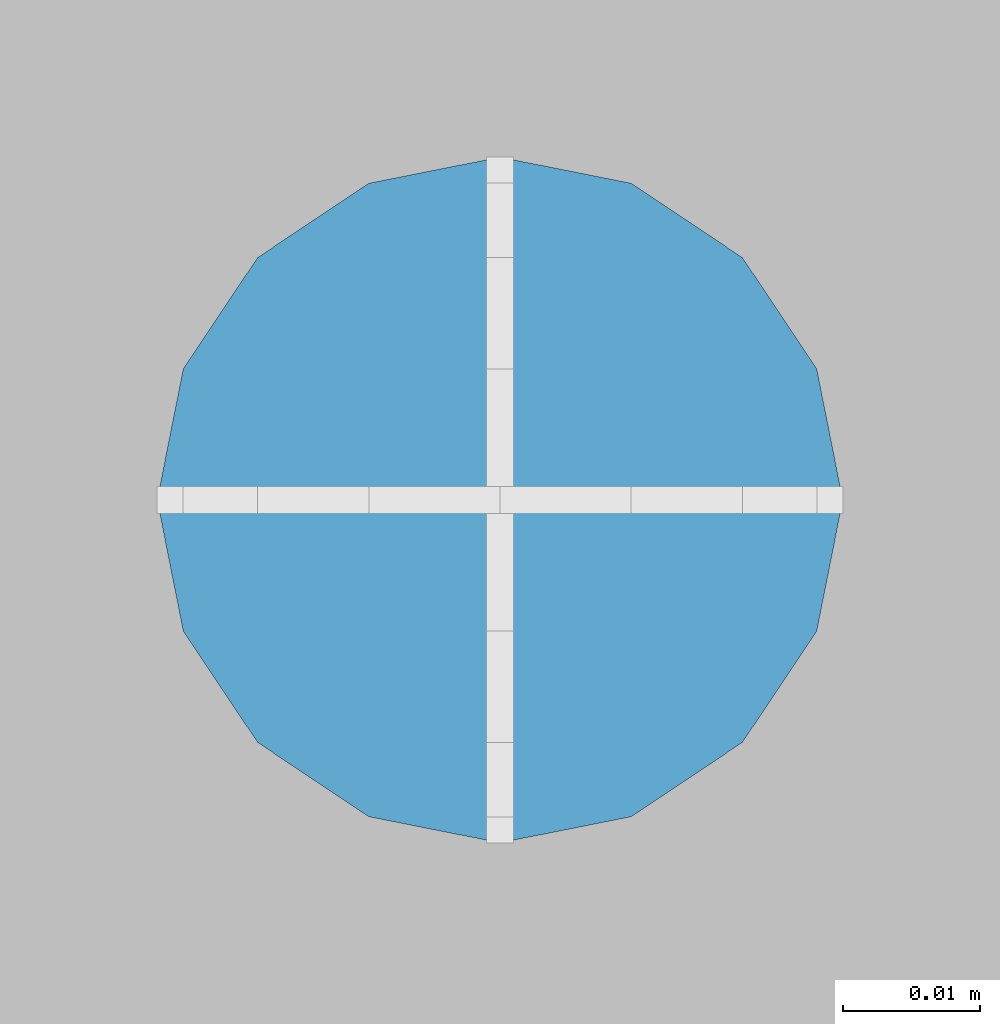
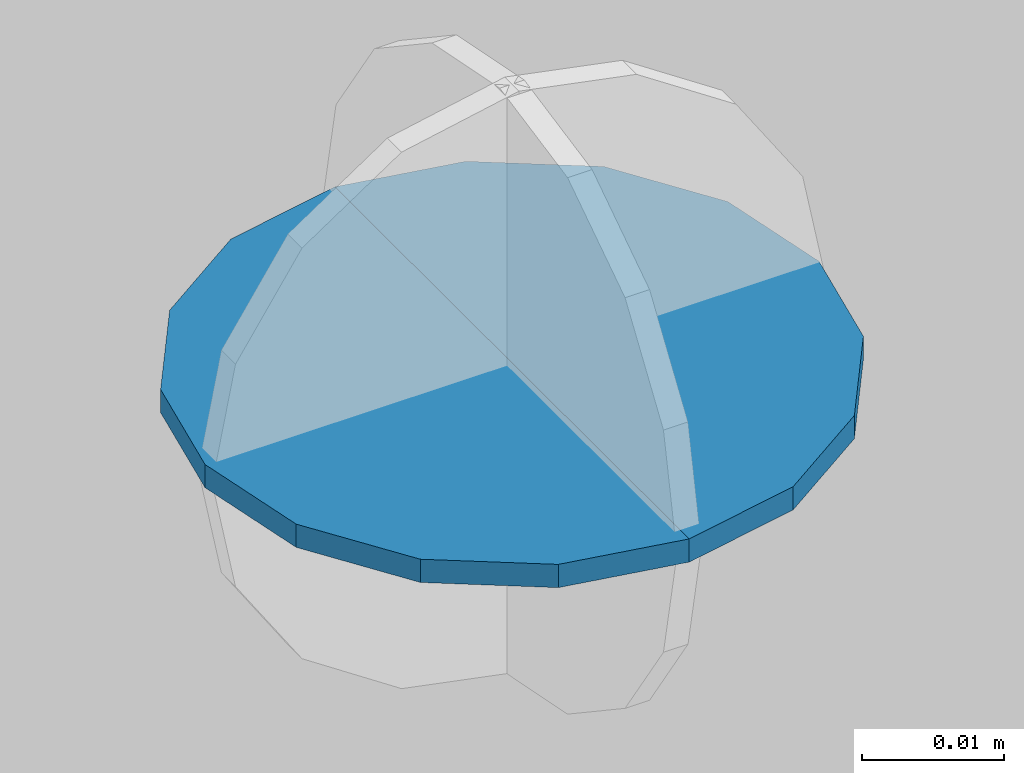
# One storey, part 74 of 350: 2 columns, 3 elements without a shape of their own.
"""IFC2X3 building model written with IfcOpenShell, lengths in millimetres."""

from ifc_helpers import new_model, si_unit, frame, origin_with_axes, place, context, subcontext, project, spatial, faceted_brep, material, type_object, element, aggregate, save


model = new_model("IFC2X3")

# Units and contexts
model_context = context("Model", 3, precision=1e-05, world=origin_with_axes())
body_context = subcontext(model_context, "Body", "Model", "MODEL_VIEW")
ifc_project = project(units=[si_unit("LENGTHUNIT", "METRE", prefix="MILLI"), si_unit("AREAUNIT", "SQUARE_METRE"), si_unit("VOLUMEUNIT", "CUBIC_METRE"), si_unit("MASSUNIT", "GRAM", prefix="KILO"), si_unit("TIMEUNIT", "SECOND"), si_unit("PLANEANGLEUNIT", "RADIAN"), si_unit("SOLIDANGLEUNIT", "STERADIAN"), si_unit("THERMODYNAMICTEMPERATUREUNIT", "DEGREE_CELSIUS"), si_unit("LUMINOUSINTENSITYUNIT", "LUMEN")], contexts=[model_context])

# Site, building, storey
site_placement = place(None, origin_with_axes())
site = spatial("IfcSite", under=ifc_project, at=site_placement, CompositionType="ELEMENT")
building_placement = place(site_placement, origin_with_axes())
building = spatial("IfcBuilding", under=site, at=building_placement, CompositionType="ELEMENT")
storey_placement = place(building_placement, origin_with_axes())
storey = spatial("IfcBuildingStorey", under=building, at=storey_placement, Name="2", CompositionType="ELEMENT", Elevation=0.0)

# Assemblies, columns
assembly_1_placement = place(storey_placement, origin_with_axes())
assembly_1 = element("IfcElementAssembly", 1, at=assembly_1_placement, inside=storey, AssemblyPlace="NOTDEFINED", PredefinedType="REINFORCEMENT_UNIT")
assembly_2_placement = place(assembly_1_placement, origin_with_axes())
assembly_2 = element("IfcElementAssembly", 2, at=assembly_2_placement, Name="Steel Assembly", AssemblyPlace="NOTDEFINED", PredefinedType="RIGID_FRAME")
ifc_material = material(Name="STEEL/Steel_Undefined")
column_type = type_object("IfcColumnType", Name="D50", PredefinedType="NOTDEFINED")
column_1_placement = place(assembly_2_placement, frame((17715.0967898142, 21654.2221004674, 86149.62804061), z_axis=(-1.0, 3.00000001838171e-08, 0.0), x_axis=(0.0, 0.0, 1.0)))
column_1 = element("IfcColumn", 3, at=column_1_placement, type_object=column_type, material=ifc_material, Name="PP", ObjectType="D50", context=body_context, shape_type="Brep", body=[
    faceted_brep([(7.27595761418343e-12, -17.6776695296576, 17.6776695296649), (7.27595761418343e-12, -23.0969883127837, 9.56708580912891), (2.00000000000728, -23.0969883127837, 9.56708580912891), (2.00000000000728, -17.6776695296576, 17.6776695296649), (1.45519152283669e-11, -9.56708580913255, 23.0969883127837), (2.00000000001455, -9.56708580913255, 23.0969883127837), (1.09139364212751e-11, 0.0, 25.0), (2.00000000001091, 0.0, 25.0), (1.45519152283669e-11, 9.56708580913255, 23.0969883127837), (2.00000000001455, 9.56708580913255, 23.0969883127837), (7.27595761418343e-12, 17.6776695296576, 17.6776695296649), (2.00000000000728, 17.6776695296576, 17.6776695296649), (7.27595761418343e-12, 23.0969883127837, 9.56708580912891), (2.00000000000728, 23.0969883127837, 9.56708580912891), (2.0, 25.0, 0.0), (0.0, 25.0, 0.0), (0.0, -25.0, 0.0), (2.0, -25.0, 0.0)], [[[0, 1, 2, 3]], [[4, 0, 3, 5]], [[6, 4, 5, 7]], [[8, 6, 7, 9]], [[10, 8, 9, 11]], [[12, 10, 11, 13]], [[12, 13, 14, 15]], [[1, 0, 4, 6, 8, 10, 12, 15, 16]], [[2, 1, 16, 17]], [[13, 11, 9, 7, 5, 3, 2, 17, 14]], [[17, 16, 15, 14]]]),
])
aggregate(assembly_2, [column_1])
assembly_3_placement = place(assembly_1_placement, origin_with_axes())
assembly_3 = element("IfcElementAssembly", 4, at=assembly_3_placement, Name="Steel Assembly", AssemblyPlace="NOTDEFINED", PredefinedType="RIGID_FRAME")
aggregate(assembly_1, [assembly_2, assembly_3])
column_2_placement = place(assembly_3_placement, frame((17715.0967898142, 21654.2221004674, 86149.62804061), z_axis=(-1.0, 3.00000001838171e-08, 0.0), x_axis=(0.0, 0.0, 1.0)))
column_2 = element("IfcColumn", 5, at=column_2_placement, type_object=column_type, material=ifc_material, Name="PP", ObjectType="D50", context=body_context, shape_type="Brep", body=[
    faceted_brep([(-3.63797880709171e-12, -23.0969883127837, -9.56708580912891), (-3.63797880709171e-12, -17.6776695296576, -17.6776695296649), (1.99999999999636, -17.6776695296576, -17.6776695296649), (1.99999999999636, -23.0969883127837, -9.56708580912891), (-1.09139364212751e-11, -9.56708580913255, -23.0969883127837), (1.99999999998909, -9.56708580913255, -23.0969883127837), (-1.09139364212751e-11, 0.0, -25.0), (1.99999999998909, 0.0, -25.0), (-1.09139364212751e-11, 9.56708580913255, -23.0969883127837), (1.99999999998909, 9.56708580913255, -23.0969883127837), (-3.63797880709171e-12, 17.6776695296576, -17.6776695296649), (1.99999999999636, 17.6776695296576, -17.6776695296649), (-3.63797880709171e-12, 23.0969883127837, -9.56708580912891), (1.99999999999636, 23.0969883127837, -9.56708580912891), (2.0, 25.0, 0.0), (2.0, -25.0, 0.0), (0.0, -25.0, 0.0), (0.0, 25.0, 0.0)], [[[0, 1, 2, 3]], [[1, 4, 5, 2]], [[4, 6, 7, 5]], [[6, 8, 9, 7]], [[8, 10, 11, 9]], [[10, 12, 13, 11]], [[3, 2, 5, 7, 9, 11, 13, 14, 15]], [[0, 3, 15, 16]], [[12, 10, 8, 6, 4, 1, 0, 16, 17]], [[13, 12, 17, 14]], [[15, 14, 17, 16]]]),
])
aggregate(assembly_3, [column_2])

save(model, "model.ifc")
